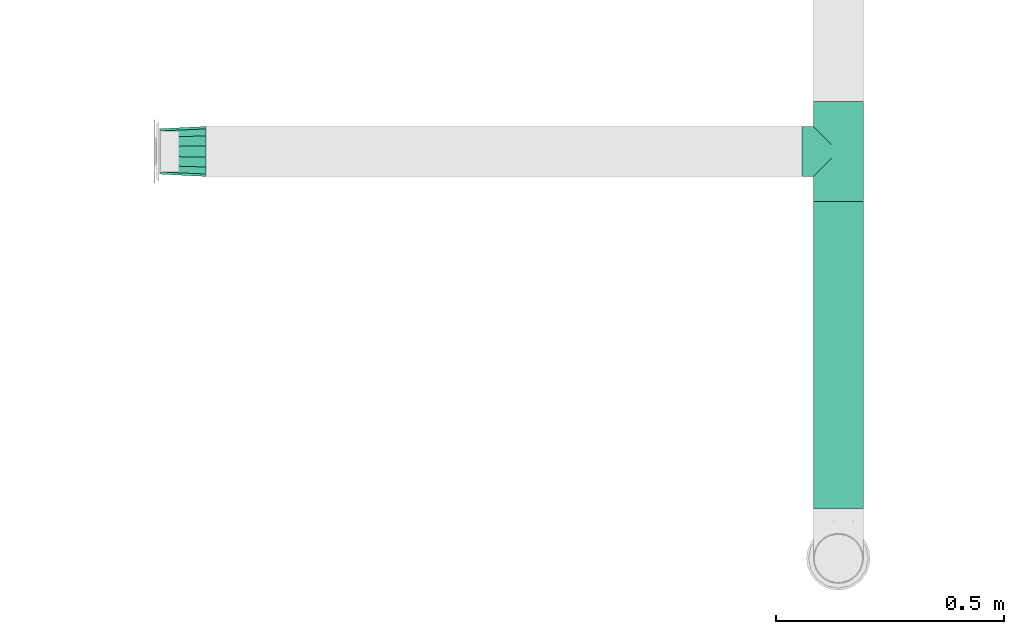
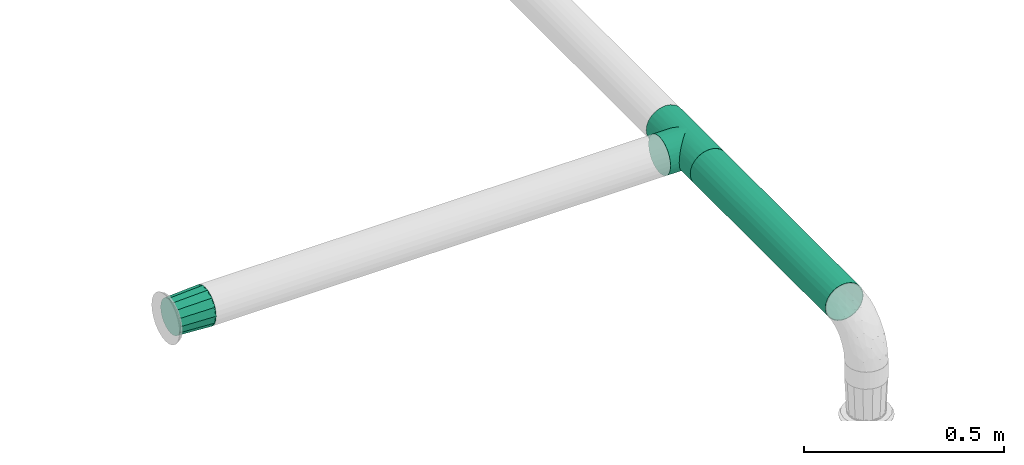
# One storey, part 60 of 123: 2 flow fittings, 1 flow segment.
"""IFC2X3 building model written with IfcOpenShell, lengths in millimetres."""

import ifcopenshell
import ifcopenshell.guid

model = None  # the IFC model being written
_history = None  # IfcOwnerHistory: only IFC2X3 demands one
_inside = {}  # id of a spatial element -> (the spatial element, [elements in it])
_under = {}  # id of a project, library or spatial element -> (it, [spatial elements below it])
_declared = {}  # id of a project -> (the project, [libraries it declares])
_typed = {}  # id of a type object -> (the type object, [elements of that type])
_made_of = {}  # id of a material, layer set ... -> (it, [elements and type objects made of it])


def new_model(schema):
    """Start an empty IFC model of exactly this schema.

    Asked for "IFC4X3", IfcOpenShell would pick the latest addendum, in which some entities
    have other attributes; the version numbers below select the first issue.
    IFC2X3 requires an IfcOwnerHistory on every rooted entity: one is made here for all.
    """
    global model, _history
    if schema == "IFC4X3":
        model = ifcopenshell.file(schema_version=(4, 3, 0, 0))
    else:
        model = ifcopenshell.file(schema=schema)
    _inside.clear()
    _under.clear()
    _declared.clear()
    _typed.clear()
    _made_of.clear()
    _history = None
    if model.schema == "IFC2X3":
        org = make("IfcOrganization", Name="unknown")
        user = make(
            "IfcPersonAndOrganization",
            ThePerson=make("IfcPerson", FamilyName="unknown"),
            TheOrganization=org,
        )
        app = make(
            "IfcApplication",
            ApplicationDeveloper=org,
            Version="unknown",
            ApplicationFullName="unknown",
            ApplicationIdentifier="unknown",
        )
        _history = make(
            "IfcOwnerHistory",
            OwningUser=user,
            OwningApplication=app,
            ChangeAction="ADDED",
            CreationDate=0,
        )
    return model


def make(cls, **values):
    """One entity of the class cls with the attributes given. An attribute that is None is left unset."""
    return model.create_entity(
        cls, **{name: value for name, value in values.items() if value is not None}
    )


def entity(cls, *values):
    """Any entity or typed value of the class cls, its attributes in the order of the schema. None: left unset."""
    e = model.create_entity(cls)
    for i, value in enumerate(values):
        if value is not None:
            e[i] = value
    return e


def rooted(cls, **values):
    """An entity with a GlobalId (a new one), such as an element, a storey or a relation."""
    return make(cls, GlobalId=ifcopenshell.guid.new(), OwnerHistory=_history, **values)


def si_unit(unit_type, name, prefix=None):
    """IfcSIUnit, for example si_unit("LENGTHUNIT", "METRE", prefix="MILLI")."""
    return make("IfcSIUnit", UnitType=unit_type, Prefix=prefix, Name=name)


def converted_unit(unit_type, name, factor, base, dimensions=None, offset=None):
    """IfcConversionBasedUnit, such as the inch: factor (a typed value) times the base unit."""
    return make(
        "IfcConversionBasedUnit"
        if offset is None
        else "IfcConversionBasedUnitWithOffset",
        ConversionOffset=offset,
        Dimensions=None
        if dimensions is None
        else entity("IfcDimensionalExponents", *dimensions),
        UnitType=unit_type,
        Name=name,
        ConversionFactor=make(
            "IfcMeasureWithUnit", ValueComponent=factor, UnitComponent=base
        ),
    )


def derived_unit(unit_type, elements):
    """IfcDerivedUnit: a product of units, each with its exponent."""
    return make(
        "IfcDerivedUnit",
        Elements=[
            make("IfcDerivedUnitElement", Unit=unit, Exponent=power)
            for unit, power in elements
        ],
        UnitType=unit_type,
    )


def assignment(units):
    """IfcUnitAssignment: the units of a project."""
    return None if units is None else make("IfcUnitAssignment", Units=units)


def point(xyz):
    """IfcCartesianPoint."""
    return None if xyz is None else make("IfcCartesianPoint", Coordinates=xyz)


def direction(xyz):
    """IfcDirection."""
    return None if xyz is None else make("IfcDirection", DirectionRatios=xyz)


def frame(location, z_axis=None, x_axis=None):
    """IfcAxis2Placement3D, a coordinate frame: its origin and axes. An axis left out is left unset."""
    return make(
        "IfcAxis2Placement3D",
        Location=point(location),
        Axis=direction(z_axis),
        RefDirection=direction(x_axis),
    )


def frame_2d(location, x_axis=None):
    """IfcAxis2Placement2D, a coordinate frame in the plane: its origin and x axis."""
    return make(
        "IfcAxis2Placement2D", Location=point(location), RefDirection=direction(x_axis)
    )


def origin_with_axes():
    """The frame at (0, 0, 0) with the z axis (0, 0, 1) and the x axis (1, 0, 0) written out."""
    return frame((0.0, 0.0, 0.0), z_axis=(0.0, 0.0, 1.0), x_axis=(1.0, 0.0, 0.0))


def origin_2d_with_axis():
    """The frame at (0, 0) in the plane with the x axis (1, 0) written out."""
    return frame_2d((0.0, 0.0), x_axis=(1.0, 0.0))


def place(relative_to, where):
    """IfcLocalPlacement: puts the frame where relative to a parent placement (None: the world)."""
    return make(
        "IfcLocalPlacement", PlacementRelTo=relative_to, RelativePlacement=where
    )


def context(
    kind, dimensions, precision=None, world=None, true_north=None, identifier=None
):
    """IfcGeometricRepresentationContext, for example the 3D "Model" context."""
    return make(
        "IfcGeometricRepresentationContext",
        ContextIdentifier=identifier,
        ContextType=kind,
        CoordinateSpaceDimension=dimensions,
        Precision=precision,
        WorldCoordinateSystem=world,
        TrueNorth=true_north,
    )


def subcontext(parent, identifier, kind, view, scale=None):
    """IfcGeometricRepresentationSubContext, for example "Body" below "Model"."""
    return make(
        "IfcGeometricRepresentationSubContext",
        ContextIdentifier=identifier,
        ContextType=kind,
        ParentContext=parent,
        TargetScale=scale,
        TargetView=view,
    )


def project(units=None, contexts=None):
    """IfcProject with its units and contexts."""
    return rooted(
        "IfcProject",
        Name="project",
        RepresentationContexts=contexts,
        UnitsInContext=assignment(units),
    )


def spatial(cls, under=None, at=None, **own):
    """A site, building, storey or space (cls), placed at a placement, below another one or the project."""
    s = rooted(cls, ObjectPlacement=at, **own)
    if under is not None:
        _under.setdefault(under.id(), (under, []))[1].append(s)
    return s


def profile(cls, at=None, kind="AREA", **sizes):
    """A parametric profile (cls). Its sizes go by their IFC names, for example OverallWidth=200.0."""
    return make(cls, ProfileType=kind, Position=at, **sizes)


def hollow_circle(**sizes):
    """IfcCircleHollowProfileDef."""
    return profile("IfcCircleHollowProfileDef", **sizes)


def extrude(swept, where, along, depth):
    """IfcExtrudedAreaSolid: the profile swept, set in the frame where, extruded along a direction by depth."""
    return make(
        "IfcExtrudedAreaSolid",
        SweptArea=swept,
        Position=where,
        ExtrudedDirection=direction(along),
        Depth=depth,
    )


def faces_of(points, faces, orient=None, outer=None):
    """IfcFace entities. A face is a list of loops; a loop is a list of indices into points, from 0.

    orient and outer hold one flag for each loop. By default every Orientation is true, the
    first loop of a face is its IfcFaceOuterBound and the others are IfcFaceBound.
    """
    made = []
    for i, loops in enumerate(faces):
        bounds = []
        for j, loop in enumerate(loops):
            is_outer = j == 0 if outer is None else outer[i][j]
            bounds.append(
                make(
                    "IfcFaceOuterBound" if is_outer else "IfcFaceBound",
                    Bound=make("IfcPolyLoop", Polygon=[points[k] for k in loop]),
                    Orientation=True if orient is None else orient[i][j],
                )
            )
        made.append(make("IfcFace", Bounds=bounds))
    return made


def open_shell(faces, orient=None, outer=None):
    """The faces of one IfcOpenShell. surface_model builds it on its shared points."""
    return ("IfcOpenShell", faces, orient, outer)


def surface_model(cls, points, shells):
    """IfcFaceBasedSurfaceModel or IfcShellBasedSurfaceModel (cls): surfaces that need not close."""
    shared = [point(p) for p in points]
    made = [make(c, CfsFaces=faces_of(shared, fs, o, b)) for c, fs, o, b in shells]
    if cls == "IfcFaceBasedSurfaceModel":
        return make(cls, FbsmFaces=made)
    return make(cls, SbsmBoundary=made)


def shape(context_of_items, identifier, shape_type, items):
    """IfcShapeRepresentation: the items that make up one representation, for example the "Body"."""
    return make(
        "IfcShapeRepresentation",
        ContextOfItems=context_of_items,
        RepresentationIdentifier=identifier,
        RepresentationType=shape_type,
        Items=items,
    )


def source(mapping_origin, context_of_items, identifier, shape_type, items):
    """IfcRepresentationMap: a shape defined once, which mapped items show again and again."""
    return make(
        "IfcRepresentationMap",
        MappingOrigin=mapping_origin,
        MappedRepresentation=shape(context_of_items, identifier, shape_type, items),
    )


def transform(
    local_origin,
    x_axis=None,
    y_axis=None,
    z_axis=None,
    scale=None,
    scale2=None,
    scale3=None,
    uniform=True,
):
    """IfcCartesianTransformationOperator3D, or its non-uniform kind. x_axis, y_axis, z_axis: its Axis1, 2, 3."""
    if uniform:
        return make(
            "IfcCartesianTransformationOperator3D",
            Axis1=direction(x_axis),
            Axis2=direction(y_axis),
            LocalOrigin=point(local_origin),
            Scale=scale,
            Axis3=direction(z_axis),
        )
    return make(
        "IfcCartesianTransformationOperator3DnonUniform",
        Axis1=direction(x_axis),
        Axis2=direction(y_axis),
        LocalOrigin=point(local_origin),
        Scale=scale,
        Axis3=direction(z_axis),
        Scale2=scale2,
        Scale3=scale3,
    )


def mapped(mapping_source, mapping_target):
    """IfcMappedItem: shows the shape of a source again, moved by a transform."""
    return make(
        "IfcMappedItem", MappingSource=mapping_source, MappingTarget=mapping_target
    )


def material(Name=None, Category=None):
    """IfcMaterial."""
    return make("IfcMaterial", Name=Name, Category=Category)


def layer(
    of_material, thickness, ventilated=None, Name=None, Category=None, Priority=None
):
    """IfcMaterialLayer: one layer of a wall or slab, of a material (None: an air gap)."""
    return make(
        "IfcMaterialLayer",
        Material=of_material,
        LayerThickness=thickness,
        IsVentilated=ventilated,
        Name=Name,
        Category=Category,
        Priority=Priority,
    )


def layer_set(layers, Name=None):
    """IfcMaterialLayerSet."""
    return make("IfcMaterialLayerSet", MaterialLayers=layers, LayerSetName=Name)


def layer_usage(for_layer_set, set_direction, sense, offset, extent=None):
    """IfcMaterialLayerSetUsage: how a layer set lies in its element."""
    return make(
        "IfcMaterialLayerSetUsage",
        ForLayerSet=for_layer_set,
        LayerSetDirection=set_direction,
        DirectionSense=sense,
        OffsetFromReferenceLine=offset,
        ReferenceExtent=extent,
    )


def made_of(thing, what):
    """Note that an element or type object is made of a material, layer set ...; save() writes the relation."""
    if what is not None:
        _made_of.setdefault(what.id(), (what, []))[1].append(thing)
    return thing


def type_object(cls, material=None, **own):
    """A type object (cls), such as IfcWallType, which elements share."""
    return made_of(rooted(cls, **own), material)


def element(
    cls,
    number,
    at=None,
    inside=None,
    cuts=None,
    type_object=None,
    material=None,
    context=None,
    identifier="Body",
    shape_type=None,
    held_by="IfcProductDefinitionShape",
    body=None,
    shapes=None,
    **own,
):
    """One element of the class cls, such as IfcWall. Its Tag is "e" and its number.

    at: its placement. inside: the storey or other place that contains it. cuts: it is an
    opening in that element (IfcRelVoidsElement). A single representation is given by context,
    identifier, shape_type and body (its items); several are given by shapes. held_by: the class
    of the entity that holds the representations. save() writes the other relations.
    """
    e = rooted(cls, Tag="e%d" % number, ObjectPlacement=at, **own)
    if body is not None:
        shapes = [shape(context, identifier, shape_type, body)]
    if shapes is not None:
        e.Representation = make(held_by, Representations=shapes)
    if inside is not None:
        _inside.setdefault(inside.id(), (inside, []))[1].append(e)
    if cuts is not None:
        rooted(
            "IfcRelVoidsElement", RelatingBuildingElement=cuts, RelatedOpeningElement=e
        )
    if type_object is not None:
        _typed.setdefault(type_object.id(), (type_object, []))[1].append(e)
    return made_of(e, material)


def aggregate(whole, parts):
    """IfcRelAggregates: a whole, such as a stair, and the parts it consists of."""
    return rooted("IfcRelAggregates", RelatingObject=whole, RelatedObjects=parts)


def save(model, path):
    """Write the relations noted so far, then the file.

    IfcRelAggregates (storeys below a building ...), IfcRelContainedInSpatialStructure (elements
    in a storey), IfcRelDefinesByType, IfcRelAssociatesMaterial and IfcRelDeclares: one each for
    every whole, place, type object, material and project.
    """
    for whole, parts in _under.values():
        aggregate(whole, parts)
    for where, things in _inside.values():
        rooted(
            "IfcRelContainedInSpatialStructure",
            RelatedElements=things,
            RelatingStructure=where,
        )
    for kind, things in _typed.values():
        rooted("IfcRelDefinesByType", RelatedObjects=things, RelatingType=kind)
    for what, things in _made_of.values():
        rooted("IfcRelAssociatesMaterial", RelatedObjects=things, RelatingMaterial=what)
    for by, libraries in _declared.values():
        rooted("IfcRelDeclares", RelatingContext=by, RelatedDefinitions=libraries)
    model.write(path)


model = new_model("IFC2X3")

# Units and contexts
model_context = context("Model", 3, precision=1e-05, world=origin_with_axes(), true_north=direction((0.0, 1.0)))
body_context = subcontext(model_context, "Body", "Model", "MODEL_VIEW")
ifc_project = project(units=[si_unit("AREAUNIT", "SQUARE_METRE"), si_unit("VOLUMEUNIT", "CUBIC_METRE", prefix="DECI"), si_unit("TIMEUNIT", "SECOND"), si_unit("THERMODYNAMICTEMPERATUREUNIT", "DEGREE_CELSIUS"), si_unit("PRESSUREUNIT", "PASCAL"), si_unit("MASSUNIT", "GRAM", prefix="KILO"), si_unit("LENGTHUNIT", "METRE", prefix="MILLI"), si_unit("POWERUNIT", "WATT"), si_unit("ELECTRICCURRENTUNIT", "AMPERE"), si_unit("ELECTRICVOLTAGEUNIT", "VOLT"), derived_unit("VOLUMETRICFLOWRATEUNIT", [(si_unit("VOLUMEUNIT", "CUBIC_METRE", prefix="DECI"), 1), (si_unit("TIMEUNIT", "SECOND"), -1)]), derived_unit("LINEARVELOCITYUNIT", [(si_unit("LENGTHUNIT", "METRE"), 1), (si_unit("TIMEUNIT", "SECOND"), -1)]), derived_unit("MASSDENSITYUNIT", [(si_unit("MASSUNIT", "GRAM", prefix="KILO"), 1), (si_unit("VOLUMEUNIT", "CUBIC_METRE"), -1)]), converted_unit("PLANEANGLEUNIT", "DEGREE", entity("IfcRatioMeasure", 0.01745), si_unit("PLANEANGLEUNIT", "RADIAN"), dimensions=[0, 0, 0, 0, 0, 0, 0])], contexts=[model_context])

# Site, building, storey
site_placement = place(None, origin_with_axes())
site = spatial("IfcSite", under=ifc_project, at=site_placement, CompositionType="ELEMENT")
building_placement = place(site_placement, origin_with_axes())
building = spatial("IfcBuilding", under=site, at=building_placement, Name="mc-building", CompositionType="ELEMENT")
storey_placement = place(building_placement, origin_with_axes())
storey = spatial("IfcBuildingStorey", under=building, at=storey_placement, Name="1. Korrus", CompositionType="ELEMENT", Elevation=0.0)

# Flow fittings
duct_fitting_type_1 = type_object("IfcDuctFittingType", PredefinedType="JUNCTION")
shared_shape_1 = source(origin_with_axes(), body_context, "Body", "SurfaceModel", [
    surface_model("IfcShellBasedSurfaceModel", [(0.0, -80.0, -55.0), (14.23505, -80.0, -53.12592), (-14.23505, -80.0, -53.12592), (-53.12592, -80.0, 14.23505), (-27.5, -80.0, -47.63139), (-47.63139, -80.0, -27.5), (-38.89087, -80.0, -38.89087), (55.0, -80.0, 0.0), (53.12592, -80.0, 14.23505), (38.89087, -80.0, -38.89087), (27.5, -80.0, -47.63139), (53.12592, -80.0, -14.23505), (47.63139, -80.0, -27.5), (-53.12592, -80.0, -14.23505), (-47.63139, -80.0, 27.5), (-38.89087, -80.0, 38.89087), (14.23505, -80.0, 53.12592), (-27.5, -80.0, 47.63139), (-14.23505, -80.0, 53.12592), (47.63139, -80.0, 27.5), (38.89087, -80.0, 38.89087), (27.5, -80.0, 47.63139), (0.0, -80.0, 55.0), (-55.0, -80.0, 0.0), (0.0, 0.0, 55.0), (-7.4066, -7.4066, 54.49901), (-14.74521, -14.74521, 52.98659), (-21.93978, -21.93978, 50.43457), (-28.89905, -28.89905, 46.79578), (-35.50357, -35.50357, 42.00591), (-41.58668, -41.58668, 35.99373), (-46.92319, -46.92319, 28.69171), (-51.19777, -51.19777, 20.0945), (-50.37866, -80.0, 20.86752), (-54.01174, -54.01174, 10.37938), (-55.0, -55.0, 0.0), (-54.06296, -80.0, 7.11752), (-54.01174, -54.01174, -10.37938), (-51.19777, -51.19777, -20.0945), (-54.06296, -80.0, -7.11752), (-46.92319, -46.92319, -28.69171), (-41.58668, -41.58668, -35.99373), (-50.37866, -80.0, -20.86752), (-35.50357, -35.50357, -42.00591), (-21.93978, -21.93978, -50.43457), (-14.74521, -14.74521, -52.98659), (-7.4066, -7.4066, -54.49901), (0.0, 0.0, -55.0), (-28.89905, -28.89905, -46.79578), (7.4066, -7.4066, -54.49901), (14.74521, -14.74521, -52.98659), (21.93978, -21.93978, -50.43457), (28.89905, -28.89905, -46.79578), (35.50357, -35.50357, -42.00591), (41.58668, -41.58668, -35.99373), (46.92319, -46.92319, -28.69171), (51.19777, -51.19777, -20.0945), (50.37866, -80.0, -20.86752), (54.01174, -54.01174, -10.37938), (55.0, -55.0, 0.0), (54.06296, -80.0, -7.11752), (54.01174, -54.01174, 10.37938), (51.19777, -51.19777, 20.0945), (54.06296, -80.0, 7.11752), (46.92319, -46.92319, 28.69171), (41.58668, -41.58668, 35.99373), (50.37866, -80.0, 20.86752), (35.50357, -35.50357, 42.00591), (21.93978, -21.93978, 50.43457), (14.74521, -14.74521, 52.98659), (7.4066, -7.4066, 54.49901), (28.89905, -28.89905, 46.79578), (-110.0, 0.0, -55.0), (-110.0, -14.23505, -53.12592), (-110.0, 14.23505, -53.12592), (-110.0, 53.12592, 14.23505), (-110.0, 27.5, -47.63139), (-110.0, 47.63139, -27.5), (-110.0, 38.89087, -38.89087), (-110.0, -55.0, 0.0), (-110.0, -53.12592, 14.23505), (-110.0, -38.89087, -38.89087), (-110.0, -27.5, -47.63139), (-110.0, -53.12592, -14.23505), (-110.0, -47.63139, -27.5), (-110.0, 53.12592, -14.23505), (-110.0, 47.63139, 27.5), (-110.0, 38.89087, 38.89087), (-110.0, -14.23505, 53.12592), (-110.0, 27.5, 47.63139), (-110.0, 14.23505, 53.12592), (-110.0, -47.63139, 27.5), (-110.0, -38.89087, 38.89087), (-110.0, -27.5, 47.63139), (-110.0, 0.0, 55.0), (-110.0, 55.0, 0.0), (110.0, 55.0, 0.0), (110.0, 0.0, -55.0), (110.0, 14.23505, -53.12592), (110.0, 27.5, -47.63139), (110.0, 38.89087, -38.89087), (110.0, 47.63139, -27.5), (110.0, -38.89087, -38.89087), (110.0, -53.12592, 14.23505), (110.0, -27.5, -47.63139), (110.0, -14.23505, -53.12592), (110.0, -47.63139, -27.5), (110.0, -53.12592, -14.23505), (110.0, -55.0, 0.0), (110.0, 53.12592, -14.23505), (110.0, 53.12592, 14.23505), (110.0, 47.63139, 27.5), (110.0, 38.89087, 38.89087), (110.0, 0.0, 55.0), (110.0, 27.5, 47.63139), (110.0, 14.23505, 53.12592), (110.0, -47.63139, 27.5), (110.0, -38.89087, 38.89087), (110.0, -27.5, 47.63139), (110.0, -14.23505, 53.12592)], [open_shell([[[0, 1, 2]], [[2, 3, 4]], [[5, 6, 3]], [[6, 4, 3]], [[2, 7, 8]], [[9, 7, 10]], [[1, 10, 7]], [[11, 7, 12]], [[9, 12, 7]], [[7, 2, 1]], [[5, 3, 13]], [[2, 14, 3]], [[2, 15, 14]], [[2, 16, 17]], [[17, 15, 2]], [[16, 18, 17]], [[2, 8, 19]], [[2, 19, 20]], [[2, 20, 21]], [[16, 2, 21]], [[16, 22, 18]], [[23, 13, 3]], [[24, 25, 22]], [[26, 27, 18]], [[25, 26, 18]], [[22, 25, 18]], [[17, 28, 29]], [[17, 18, 27]], [[17, 29, 15]], [[28, 17, 27]], [[30, 31, 14]], [[32, 3, 33]], [[32, 34, 3]], [[35, 36, 34]], [[31, 32, 14]], [[15, 30, 14]], [[34, 36, 3]], [[33, 14, 32]], [[36, 35, 23]], [[30, 15, 29]], [[37, 38, 13]], [[37, 13, 39]], [[40, 41, 5]], [[38, 5, 42]], [[38, 40, 5]], [[37, 39, 35]], [[35, 39, 23]], [[13, 38, 42]], [[41, 6, 5]], [[41, 43, 6]], [[44, 45, 2]], [[46, 47, 0]], [[45, 46, 2]], [[43, 48, 4]], [[44, 4, 48]], [[44, 2, 4]], [[46, 0, 2]], [[43, 4, 6]], [[47, 49, 0]], [[50, 51, 1]], [[49, 50, 1]], [[0, 49, 1]], [[10, 52, 53]], [[10, 1, 51]], [[10, 53, 9]], [[52, 10, 51]], [[54, 55, 12]], [[56, 11, 57]], [[56, 58, 11]], [[59, 60, 58]], [[55, 56, 12]], [[9, 54, 12]], [[58, 60, 11]], [[57, 12, 56]], [[60, 59, 7]], [[54, 9, 53]], [[61, 62, 8]], [[61, 8, 63]], [[64, 65, 19]], [[62, 19, 66]], [[62, 64, 19]], [[61, 63, 59]], [[7, 59, 63]], [[62, 66, 8]], [[65, 20, 19]], [[65, 67, 20]], [[68, 69, 16]], [[70, 24, 22]], [[69, 70, 16]], [[67, 71, 21]], [[68, 21, 71]], [[68, 16, 21]], [[70, 22, 16]], [[67, 21, 20]], [[72, 73, 74]], [[74, 75, 76]], [[77, 78, 75]], [[76, 75, 78]], [[74, 79, 80]], [[81, 79, 82]], [[73, 82, 79]], [[83, 79, 84]], [[81, 84, 79]], [[79, 74, 73]], [[77, 75, 85]], [[74, 86, 75]], [[74, 87, 86]], [[74, 88, 89]], [[89, 87, 74]], [[88, 90, 89]], [[74, 91, 92]], [[91, 74, 80]], [[92, 93, 74]], [[74, 93, 88]], [[88, 94, 90]], [[95, 85, 75]], [[96, 97, 98]], [[99, 96, 98]], [[96, 100, 101]], [[100, 96, 99]], [[102, 97, 103]], [[97, 102, 104]], [[104, 105, 97]], [[102, 103, 106]], [[106, 103, 107]], [[108, 107, 103]], [[109, 96, 101]], [[110, 111, 97]], [[97, 111, 112]], [[113, 97, 114]], [[97, 112, 114]], [[113, 114, 115]], [[116, 103, 97]], [[117, 116, 97]], [[118, 117, 97]], [[119, 118, 97]], [[119, 97, 113]], [[96, 110, 97]], [[24, 113, 115]], [[89, 115, 114]], [[94, 24, 90]], [[90, 24, 115]], [[115, 89, 90]], [[114, 87, 89]], [[86, 112, 111]], [[75, 111, 110]], [[95, 110, 96]], [[87, 112, 86]], [[86, 111, 75]], [[110, 95, 75]], [[112, 87, 114]], [[85, 96, 109]], [[77, 109, 101]], [[95, 96, 85]], [[85, 109, 77]], [[101, 78, 77]], [[101, 100, 78]], [[76, 100, 99]], [[74, 99, 98]], [[47, 98, 97]], [[76, 99, 74]], [[47, 72, 74]], [[98, 47, 74]], [[100, 76, 78]], [[47, 46, 72]], [[45, 44, 73]], [[46, 45, 73]], [[72, 46, 73]], [[82, 48, 43]], [[82, 73, 44]], [[82, 43, 81]], [[48, 82, 44]], [[41, 40, 84]], [[38, 37, 83]], [[40, 38, 84]], [[81, 41, 84]], [[37, 79, 83]], [[83, 84, 38]], [[79, 37, 35]], [[41, 81, 43]], [[49, 97, 105]], [[105, 104, 51]], [[53, 104, 102]], [[53, 52, 104]], [[49, 47, 97]], [[51, 50, 105]], [[52, 51, 104]], [[49, 105, 50]], [[54, 102, 106]], [[56, 106, 107]], [[58, 107, 108]], [[55, 54, 106]], [[58, 56, 107]], [[59, 58, 108]], [[55, 106, 56]], [[102, 54, 53]], [[34, 32, 80]], [[31, 30, 91]], [[32, 31, 91]], [[35, 34, 79]], [[80, 79, 34]], [[32, 91, 80]], [[30, 92, 91]], [[30, 29, 92]], [[27, 26, 88]], [[25, 24, 94]], [[26, 25, 88]], [[29, 28, 93]], [[27, 93, 28]], [[27, 88, 93]], [[25, 94, 88]], [[29, 93, 92]], [[61, 108, 103]], [[62, 103, 116]], [[65, 116, 117]], [[61, 59, 108]], [[64, 62, 116]], [[65, 64, 116]], [[61, 103, 62]], [[117, 67, 65]], [[71, 67, 118]], [[118, 67, 117]], [[68, 118, 119]], [[70, 119, 113]], [[68, 71, 118]], [[70, 69, 119]], [[24, 70, 113]], [[68, 119, 69]]])]),
])
flow_fitting_1_placement = place(storey_placement, frame((12366.76802, 9877.62755, 2465.0), z_axis=(0.0, 0.0, 1.0), x_axis=(0.0, -1.0, 0.0)))
element("IfcFlowFitting", 1, at=flow_fitting_1_placement, inside=storey, type_object=duct_fitting_type_1, context=body_context, shape_type="MappedRepresentation", body=[
    mapped(shared_shape_1, transform((0.0, 0.0, 0.0), scale=1.0)),
])
duct_fitting_type_2 = type_object("IfcDuctFittingType", PredefinedType="TRANSITION")
shared_shape_2 = source(origin_with_axes(), body_context, "Body", "SurfaceModel", [
    surface_model("IfcShellBasedSurfaceModel", [(0.0, 12.94095, 48.29629), (0.0, -35.35534, 35.35534), (0.0, 0.0, 50.0), (0.0, 35.35534, 35.35534), (0.0, 25.0, 43.30127), (0.0, 43.30127, 25.0), (0.0, 48.29629, 12.94095), (0.0, -12.94095, 48.29629), (0.0, -25.0, 43.30127), (0.0, -48.29629, 12.94095), (0.0, -43.30127, 25.0), (0.0, -25.0, -43.30127), (0.0, -48.29629, -12.94095), (0.0, -50.0, 0.0), (0.0, 48.29629, -12.94095), (0.0, 12.94095, -48.29629), (0.0, 43.30127, -25.0), (0.0, 35.35534, -35.35534), (0.0, 25.0, -43.30127), (0.0, -35.35534, -35.35534), (0.0, -43.30127, -25.0), (0.0, -12.94095, -48.29629), (0.0, 0.0, -50.0), (0.0, 50.0, 0.0), (100.0, -55.0, 0.0), (100.0, -12.23865, 53.62104), (100.0, -34.29194, 43.00073), (100.0, 49.55329, -23.86361), (100.0, 12.23865, 53.62104), (100.0, 34.29194, 43.00073), (100.0, 55.0, 0.0), (100.0, 49.55329, 23.86361), (100.0, -49.55329, 23.86361), (100.0, 12.23865, -53.62104), (100.0, -49.55329, -23.86361), (100.0, -34.29194, -43.00073), (100.0, 34.29194, -43.00073), (100.0, -12.23865, -53.62104), (0.0, 11.12605, 48.7464), (0.0, -11.12605, 48.7464), (0.0, 31.17449, 39.09157), (0.0, -45.04844, -21.69419), (0.0, -45.04844, 21.69419), (0.0, -31.17449, 39.09157), (0.0, 45.04844, 21.69419), (0.0, 45.04844, -21.69419), (0.0, 31.17449, -39.09157), (0.0, -31.17449, -39.09157), (0.0, -11.12605, -48.7464), (0.0, 11.12605, -48.7464), (0.0, -47.52422, -10.84709), (100.0, -41.92261, -33.43217), (0.0, -38.11147, -30.39288), (100.0, 41.92261, -33.43217), (0.0, 38.11147, -30.39288), (0.0, -21.15027, -43.91899), (100.0, -23.2653, -48.31088), (100.0, -52.32388, -11.72483), (100.0, 0.0, -53.62104), (0.0, 0.0, -48.7464), (100.0, 23.2653, -48.31088), (0.0, 21.15027, -43.91899), (100.0, 52.32388, -11.72483), (0.0, 47.52422, -10.84709), (0.0, 47.52422, 10.84709), (100.0, 41.92261, 33.43217), (0.0, 38.11147, 30.39288), (100.0, -41.92261, 33.43217), (0.0, -38.11147, 30.39288), (0.0, 21.15027, 43.91899), (100.0, 23.2653, 48.31088), (100.0, 52.32388, 11.72483), (100.0, 0.0, 53.62104), (0.0, 0.0, 48.7464), (100.0, -23.2653, 48.31088), (0.0, -21.15027, 43.91899), (100.0, -52.32388, 11.72483), (0.0, -47.52422, 10.84709), (100.0, 27.5, -47.63139), (100.0, 0.0, -55.0), (100.0, 14.23505, -53.12592), (100.0, 38.89087, -38.89087), (100.0, -27.5, -47.63139), (100.0, 47.63139, -27.5), (100.0, 53.12592, -14.23505), (100.0, -14.23505, -53.12592), (100.0, -47.63139, -27.5), (100.0, -38.89087, -38.89087), (100.0, -53.12592, -14.23505), (100.0, 53.12592, 14.23505), (100.0, 47.63139, 27.5), (100.0, 27.5, 47.63139), (100.0, 38.89087, 38.89087), (100.0, 14.23505, 53.12592), (100.0, 0.0, 55.0), (100.0, -47.63139, 27.5), (100.0, -53.12592, 14.23505), (100.0, -27.5, 47.63139), (100.0, -38.89087, 38.89087), (100.0, -14.23505, 53.12592), (98.0, 0.0, 55.0), (98.0, 14.23505, 53.12592), (98.0, 27.5, 47.63139), (98.0, 38.89087, 38.89087), (98.0, 47.63139, 27.5), (98.0, -47.63139, 27.5), (98.0, 53.12592, -14.23505), (98.0, -27.5, 47.63139), (98.0, -14.23505, 53.12592), (98.0, -38.89087, 38.89087), (98.0, -55.0, 0.0), (98.0, -53.12592, 14.23505), (98.0, 53.12592, 14.23505), (98.0, 47.63139, -27.5), (98.0, -27.5, -47.63139), (98.0, 0.0, -55.0), (98.0, 38.89087, -38.89087), (98.0, 27.5, -47.63139), (98.0, 14.23505, -53.12592), (98.0, -47.63139, -27.5), (98.0, -38.89087, -38.89087), (98.0, -53.12592, -14.23505), (98.0, -14.23505, -53.12592), (98.0, 55.0, 0.0), (2.0, 12.94095, -48.29629), (2.0, 25.0, -43.30127), (2.0, 35.35534, -35.35534), (2.0, 43.30127, -25.0), (2.0, 48.29629, -12.94095), (2.0, 0.0, -50.0), (2.0, 50.0, 0.0), (2.0, -25.0, -43.30127), (2.0, -12.94095, -48.29629), (2.0, -35.35534, -35.35534), (2.0, -48.29629, -12.94095), (2.0, -43.30127, -25.0), (2.0, -48.29629, 12.94095), (2.0, 48.29629, 12.94095), (2.0, 43.30127, 25.0), (2.0, 35.35534, 35.35534), (2.0, -35.35534, 35.35534), (2.0, 12.94095, 48.29629), (2.0, 25.0, 43.30127), (2.0, 0.0, 50.0), (2.0, -43.30127, 25.0), (2.0, -50.0, 0.0), (2.0, -12.94095, 48.29629), (2.0, -25.0, 43.30127)], [open_shell([[[0, 1, 2]], [[3, 0, 4]], [[3, 5, 6]], [[0, 3, 1]], [[6, 1, 3]], [[7, 1, 8]], [[7, 2, 1]], [[1, 9, 10]], [[9, 1, 11]], [[12, 13, 9]], [[11, 1, 6]], [[6, 14, 11]], [[15, 14, 16]], [[17, 18, 15]], [[17, 15, 16]], [[11, 14, 15]], [[12, 19, 20]], [[19, 12, 11]], [[15, 21, 11]], [[12, 9, 11]], [[22, 21, 15]], [[14, 6, 23]], [[24, 25, 26]], [[25, 27, 28]], [[29, 28, 27]], [[27, 30, 31]], [[31, 29, 27]], [[24, 26, 32]], [[33, 24, 34]], [[33, 34, 35]], [[36, 27, 33]], [[33, 27, 24]], [[35, 37, 33]], [[24, 27, 25]], [[38, 23, 39]], [[40, 23, 38]], [[41, 42, 43]], [[41, 13, 42]], [[23, 43, 39]], [[40, 44, 23]], [[41, 23, 45]], [[41, 45, 46]], [[47, 41, 48]], [[49, 48, 41]], [[41, 46, 49]], [[23, 41, 43]], [[34, 50, 41]], [[47, 51, 52]], [[45, 27, 53]], [[36, 54, 53]], [[55, 48, 56]], [[34, 57, 50]], [[57, 13, 50]], [[13, 57, 24]], [[55, 35, 47]], [[35, 51, 47]], [[51, 41, 52]], [[58, 59, 49]], [[60, 61, 46]], [[37, 59, 58]], [[62, 63, 23]], [[35, 55, 56]], [[23, 30, 62]], [[53, 54, 45]], [[48, 37, 56]], [[33, 49, 61]], [[49, 33, 58]], [[54, 36, 46]], [[63, 27, 45]], [[34, 41, 51]], [[33, 61, 60]], [[48, 59, 37]], [[27, 63, 62]], [[46, 36, 60]], [[31, 64, 44]], [[40, 65, 66]], [[42, 32, 67]], [[26, 68, 67]], [[69, 38, 70]], [[31, 71, 64]], [[71, 23, 64]], [[23, 71, 30]], [[69, 29, 40]], [[29, 65, 40]], [[65, 44, 66]], [[72, 73, 39]], [[74, 75, 43]], [[28, 73, 72]], [[76, 77, 13]], [[29, 69, 70]], [[13, 24, 76]], [[67, 68, 42]], [[38, 28, 70]], [[25, 39, 75]], [[39, 25, 72]], [[68, 26, 43]], [[77, 32, 42]], [[31, 44, 65]], [[25, 75, 74]], [[38, 73, 28]], [[32, 77, 76]], [[43, 26, 74]], [[78, 79, 80]], [[81, 82, 78]], [[82, 83, 84]], [[81, 83, 82]], [[30, 82, 84]], [[79, 82, 85]], [[79, 78, 82]], [[82, 86, 87]], [[82, 30, 86]], [[24, 88, 86]], [[86, 30, 89]], [[90, 24, 89]], [[91, 90, 92]], [[91, 93, 94]], [[90, 91, 24]], [[94, 95, 91]], [[24, 95, 96]], [[24, 91, 95]], [[94, 97, 98]], [[98, 95, 94]], [[97, 94, 99]], [[89, 24, 86]], [[100, 101, 102]], [[100, 102, 103]], [[100, 104, 105]], [[104, 100, 103]], [[106, 105, 104]], [[100, 107, 108]], [[100, 109, 107]], [[105, 110, 111]], [[109, 100, 105]], [[105, 106, 110]], [[106, 104, 112]], [[106, 113, 110]], [[113, 114, 110]], [[115, 116, 117]], [[113, 116, 115]], [[117, 118, 115]], [[119, 114, 120]], [[121, 110, 119]], [[114, 115, 122]], [[119, 110, 114]], [[115, 114, 113]], [[123, 106, 112]], [[121, 88, 110]], [[119, 86, 121]], [[82, 120, 114]], [[119, 120, 87]], [[85, 114, 122]], [[121, 86, 88]], [[88, 24, 110]], [[85, 82, 114]], [[87, 120, 82]], [[87, 86, 119]], [[79, 85, 122]], [[122, 115, 79]], [[118, 80, 115]], [[117, 78, 118]], [[83, 116, 113]], [[117, 116, 81]], [[84, 113, 106]], [[117, 81, 78]], [[78, 80, 118]], [[30, 84, 106]], [[83, 113, 84]], [[83, 81, 116]], [[123, 30, 106]], [[115, 80, 79]], [[112, 89, 123]], [[104, 90, 112]], [[91, 103, 102]], [[104, 103, 92]], [[93, 102, 101]], [[112, 90, 89]], [[89, 30, 123]], [[93, 91, 102]], [[92, 103, 91]], [[92, 90, 104]], [[94, 93, 101]], [[101, 100, 94]], [[108, 99, 100]], [[107, 97, 108]], [[95, 109, 105]], [[107, 109, 98]], [[96, 105, 111]], [[107, 98, 97]], [[97, 99, 108]], [[24, 96, 111]], [[95, 105, 96]], [[95, 98, 109]], [[110, 24, 111]], [[100, 99, 94]], [[124, 125, 126]], [[124, 126, 127]], [[124, 128, 129]], [[128, 124, 127]], [[129, 128, 130]], [[129, 131, 132]], [[129, 130, 131]], [[133, 134, 135]], [[134, 133, 131]], [[131, 136, 134]], [[131, 130, 137]], [[137, 138, 139]], [[140, 137, 139]], [[140, 139, 141]], [[141, 139, 142]], [[140, 141, 143]], [[136, 140, 144]], [[145, 134, 136]], [[140, 146, 147]], [[131, 140, 136]], [[143, 146, 140]], [[131, 137, 140]], [[12, 134, 13]], [[20, 135, 12]], [[131, 19, 11]], [[20, 19, 133]], [[132, 11, 21]], [[12, 135, 134]], [[134, 145, 13]], [[132, 131, 11]], [[133, 19, 131]], [[133, 135, 20]], [[129, 132, 21]], [[21, 22, 129]], [[15, 124, 22]], [[18, 125, 15]], [[127, 17, 16]], [[18, 17, 126]], [[128, 16, 14]], [[18, 126, 125]], [[125, 124, 15]], [[130, 128, 14]], [[127, 16, 128]], [[127, 126, 17]], [[23, 130, 14]], [[22, 124, 129]], [[6, 137, 23]], [[5, 138, 6]], [[142, 3, 4]], [[5, 3, 139]], [[141, 4, 0]], [[6, 138, 137]], [[137, 130, 23]], [[141, 142, 4]], [[139, 3, 142]], [[139, 138, 5]], [[143, 141, 0]], [[0, 2, 143]], [[7, 146, 2]], [[8, 147, 7]], [[144, 1, 10]], [[8, 1, 140]], [[136, 10, 9]], [[8, 140, 147]], [[147, 146, 7]], [[145, 136, 9]], [[144, 10, 136]], [[144, 140, 1]], [[13, 145, 9]], [[2, 146, 143]]])]),
])
flow_fitting_2_placement = place(storey_placement, frame((10877.54782, 9877.62755, 2465.0), z_axis=(0.0, 0.0, 1.0), x_axis=(1.0, 0.0, 0.0)))
element("IfcFlowFitting", 2, at=flow_fitting_2_placement, inside=storey, type_object=duct_fitting_type_2, context=body_context, shape_type="MappedRepresentation", body=[
    mapped(shared_shape_2, transform((0.0, 0.0, 0.0), scale=1.0)),
])

# Flow segment
ifc_material = material(Name="FZ1")
ifc_layer = layer(ifc_material, 0.0)
ifc_layer_set = layer_set([ifc_layer], Name="FZ1")
ifc_layer_usage = layer_usage(ifc_layer_set, "AXIS1", "POSITIVE", 0.0)
duct_segment_type = type_object("IfcDuctSegmentType", PredefinedType="RIGIDSEGMENT")
shared_shape_3 = source(origin_with_axes(), body_context, "Body", "SweptSolid", [
    extrude(hollow_circle(Radius=55.0, WallThickness=2.0, at=origin_2d_with_axis()), frame((0.0, 0.0, 0.0), z_axis=(1.0, 0.0, 0.0), x_axis=(0.0, 1.0, 0.0)), (0.0, 0.0, 1.0), 674.1),
])
flow_segment_placement = place(storey_placement, frame((12366.76802, 9767.62755, 2465.0), z_axis=(0.0, 0.0, 1.0), x_axis=(0.0, -1.0, 0.0)))
element("IfcFlowSegment", 3, at=flow_segment_placement, inside=storey, type_object=duct_segment_type, material=ifc_layer_usage, context=body_context, shape_type="MappedRepresentation", body=[
    mapped(shared_shape_3, transform((0.0, 0.0, 0.0), scale=1.0)),
])

save(model, "model.ifc")
